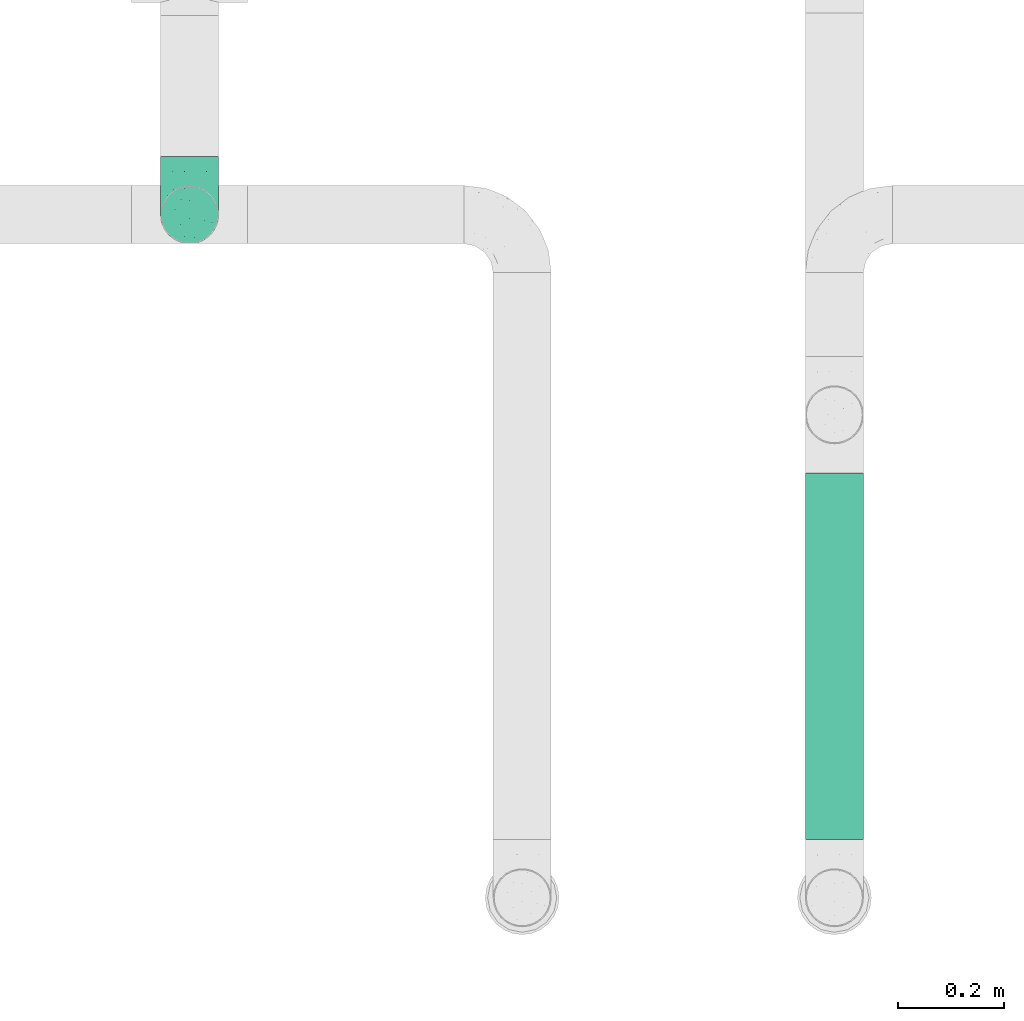
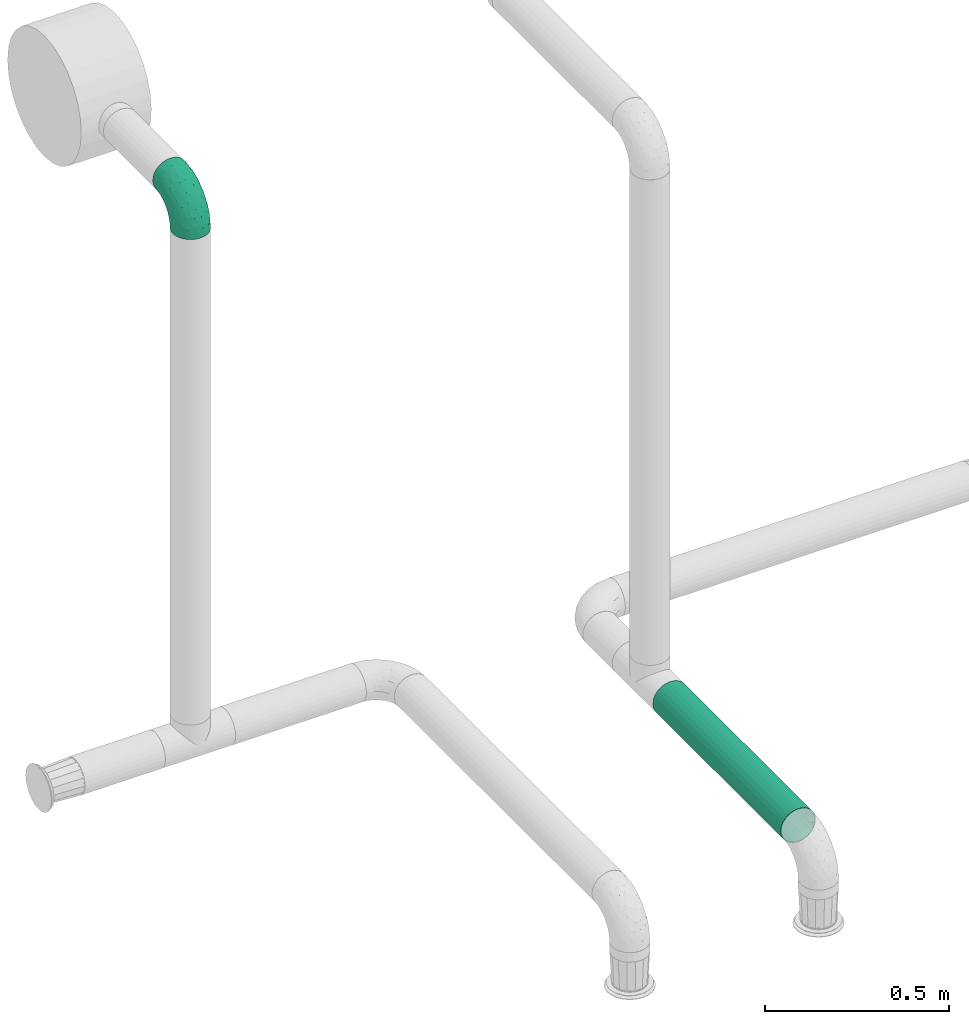
# One storey, part 80 of 103: 1 flow fitting, 1 flow segment.
"""IFC2X3 building model written with IfcOpenShell, lengths in millimetres."""

import ifcopenshell
import ifcopenshell.guid

model = None  # the IFC model being written
_history = None  # IfcOwnerHistory: only IFC2X3 demands one
_inside = {}  # id of a spatial element -> (the spatial element, [elements in it])
_under = {}  # id of a project, library or spatial element -> (it, [spatial elements below it])
_declared = {}  # id of a project -> (the project, [libraries it declares])
_typed = {}  # id of a type object -> (the type object, [elements of that type])
_made_of = {}  # id of a material, layer set ... -> (it, [elements and type objects made of it])


def new_model(schema):
    """Start an empty IFC model of exactly this schema.

    Asked for "IFC4X3", IfcOpenShell would pick the latest addendum, in which some entities
    have other attributes; the version numbers below select the first issue.
    IFC2X3 requires an IfcOwnerHistory on every rooted entity: one is made here for all.
    """
    global model, _history
    if schema == "IFC4X3":
        model = ifcopenshell.file(schema_version=(4, 3, 0, 0))
    else:
        model = ifcopenshell.file(schema=schema)
    _inside.clear()
    _under.clear()
    _declared.clear()
    _typed.clear()
    _made_of.clear()
    _history = None
    if model.schema == "IFC2X3":
        org = make("IfcOrganization", Name="unknown")
        user = make(
            "IfcPersonAndOrganization",
            ThePerson=make("IfcPerson", FamilyName="unknown"),
            TheOrganization=org,
        )
        app = make(
            "IfcApplication",
            ApplicationDeveloper=org,
            Version="unknown",
            ApplicationFullName="unknown",
            ApplicationIdentifier="unknown",
        )
        _history = make(
            "IfcOwnerHistory",
            OwningUser=user,
            OwningApplication=app,
            ChangeAction="ADDED",
            CreationDate=0,
        )
    return model


def make(cls, **values):
    """One entity of the class cls with the attributes given. An attribute that is None is left unset."""
    return model.create_entity(
        cls, **{name: value for name, value in values.items() if value is not None}
    )


def entity(cls, *values):
    """Any entity or typed value of the class cls, its attributes in the order of the schema. None: left unset."""
    e = model.create_entity(cls)
    for i, value in enumerate(values):
        if value is not None:
            e[i] = value
    return e


def rooted(cls, **values):
    """An entity with a GlobalId (a new one), such as an element, a storey or a relation."""
    return make(cls, GlobalId=ifcopenshell.guid.new(), OwnerHistory=_history, **values)


def si_unit(unit_type, name, prefix=None):
    """IfcSIUnit, for example si_unit("LENGTHUNIT", "METRE", prefix="MILLI")."""
    return make("IfcSIUnit", UnitType=unit_type, Prefix=prefix, Name=name)


def converted_unit(unit_type, name, factor, base, dimensions=None, offset=None):
    """IfcConversionBasedUnit, such as the inch: factor (a typed value) times the base unit."""
    return make(
        "IfcConversionBasedUnit"
        if offset is None
        else "IfcConversionBasedUnitWithOffset",
        ConversionOffset=offset,
        Dimensions=None
        if dimensions is None
        else entity("IfcDimensionalExponents", *dimensions),
        UnitType=unit_type,
        Name=name,
        ConversionFactor=make(
            "IfcMeasureWithUnit", ValueComponent=factor, UnitComponent=base
        ),
    )


def derived_unit(unit_type, elements):
    """IfcDerivedUnit: a product of units, each with its exponent."""
    return make(
        "IfcDerivedUnit",
        Elements=[
            make("IfcDerivedUnitElement", Unit=unit, Exponent=power)
            for unit, power in elements
        ],
        UnitType=unit_type,
    )


def assignment(units):
    """IfcUnitAssignment: the units of a project."""
    return None if units is None else make("IfcUnitAssignment", Units=units)


def point(xyz):
    """IfcCartesianPoint."""
    return None if xyz is None else make("IfcCartesianPoint", Coordinates=xyz)


def direction(xyz):
    """IfcDirection."""
    return None if xyz is None else make("IfcDirection", DirectionRatios=xyz)


def frame(location, z_axis=None, x_axis=None):
    """IfcAxis2Placement3D, a coordinate frame: its origin and axes. An axis left out is left unset."""
    return make(
        "IfcAxis2Placement3D",
        Location=point(location),
        Axis=direction(z_axis),
        RefDirection=direction(x_axis),
    )


def frame_2d(location, x_axis=None):
    """IfcAxis2Placement2D, a coordinate frame in the plane: its origin and x axis."""
    return make(
        "IfcAxis2Placement2D", Location=point(location), RefDirection=direction(x_axis)
    )


def origin_with_axes():
    """The frame at (0, 0, 0) with the z axis (0, 0, 1) and the x axis (1, 0, 0) written out."""
    return frame((0.0, 0.0, 0.0), z_axis=(0.0, 0.0, 1.0), x_axis=(1.0, 0.0, 0.0))


def origin_2d_with_axis():
    """The frame at (0, 0) in the plane with the x axis (1, 0) written out."""
    return frame_2d((0.0, 0.0), x_axis=(1.0, 0.0))


def place(relative_to, where):
    """IfcLocalPlacement: puts the frame where relative to a parent placement (None: the world)."""
    return make(
        "IfcLocalPlacement", PlacementRelTo=relative_to, RelativePlacement=where
    )


def context(
    kind, dimensions, precision=None, world=None, true_north=None, identifier=None
):
    """IfcGeometricRepresentationContext, for example the 3D "Model" context."""
    return make(
        "IfcGeometricRepresentationContext",
        ContextIdentifier=identifier,
        ContextType=kind,
        CoordinateSpaceDimension=dimensions,
        Precision=precision,
        WorldCoordinateSystem=world,
        TrueNorth=true_north,
    )


def subcontext(parent, identifier, kind, view, scale=None):
    """IfcGeometricRepresentationSubContext, for example "Body" below "Model"."""
    return make(
        "IfcGeometricRepresentationSubContext",
        ContextIdentifier=identifier,
        ContextType=kind,
        ParentContext=parent,
        TargetScale=scale,
        TargetView=view,
    )


def project(units=None, contexts=None):
    """IfcProject with its units and contexts."""
    return rooted(
        "IfcProject",
        Name="project",
        RepresentationContexts=contexts,
        UnitsInContext=assignment(units),
    )


def spatial(cls, under=None, at=None, **own):
    """A site, building, storey or space (cls), placed at a placement, below another one or the project."""
    s = rooted(cls, ObjectPlacement=at, **own)
    if under is not None:
        _under.setdefault(under.id(), (under, []))[1].append(s)
    return s


def profile(cls, at=None, kind="AREA", **sizes):
    """A parametric profile (cls). Its sizes go by their IFC names, for example OverallWidth=200.0."""
    return make(cls, ProfileType=kind, Position=at, **sizes)


def hollow_circle(**sizes):
    """IfcCircleHollowProfileDef."""
    return profile("IfcCircleHollowProfileDef", **sizes)


def extrude(swept, where, along, depth):
    """IfcExtrudedAreaSolid: the profile swept, set in the frame where, extruded along a direction by depth."""
    return make(
        "IfcExtrudedAreaSolid",
        SweptArea=swept,
        Position=where,
        ExtrudedDirection=direction(along),
        Depth=depth,
    )


def faces_of(points, faces, orient=None, outer=None):
    """IfcFace entities. A face is a list of loops; a loop is a list of indices into points, from 0.

    orient and outer hold one flag for each loop. By default every Orientation is true, the
    first loop of a face is its IfcFaceOuterBound and the others are IfcFaceBound.
    """
    made = []
    for i, loops in enumerate(faces):
        bounds = []
        for j, loop in enumerate(loops):
            is_outer = j == 0 if outer is None else outer[i][j]
            bounds.append(
                make(
                    "IfcFaceOuterBound" if is_outer else "IfcFaceBound",
                    Bound=make("IfcPolyLoop", Polygon=[points[k] for k in loop]),
                    Orientation=True if orient is None else orient[i][j],
                )
            )
        made.append(make("IfcFace", Bounds=bounds))
    return made


def open_shell(faces, orient=None, outer=None):
    """The faces of one IfcOpenShell. surface_model builds it on its shared points."""
    return ("IfcOpenShell", faces, orient, outer)


def surface_model(cls, points, shells):
    """IfcFaceBasedSurfaceModel or IfcShellBasedSurfaceModel (cls): surfaces that need not close."""
    shared = [point(p) for p in points]
    made = [make(c, CfsFaces=faces_of(shared, fs, o, b)) for c, fs, o, b in shells]
    if cls == "IfcFaceBasedSurfaceModel":
        return make(cls, FbsmFaces=made)
    return make(cls, SbsmBoundary=made)


def shape(context_of_items, identifier, shape_type, items):
    """IfcShapeRepresentation: the items that make up one representation, for example the "Body"."""
    return make(
        "IfcShapeRepresentation",
        ContextOfItems=context_of_items,
        RepresentationIdentifier=identifier,
        RepresentationType=shape_type,
        Items=items,
    )


def source(mapping_origin, context_of_items, identifier, shape_type, items):
    """IfcRepresentationMap: a shape defined once, which mapped items show again and again."""
    return make(
        "IfcRepresentationMap",
        MappingOrigin=mapping_origin,
        MappedRepresentation=shape(context_of_items, identifier, shape_type, items),
    )


def transform(
    local_origin,
    x_axis=None,
    y_axis=None,
    z_axis=None,
    scale=None,
    scale2=None,
    scale3=None,
    uniform=True,
):
    """IfcCartesianTransformationOperator3D, or its non-uniform kind. x_axis, y_axis, z_axis: its Axis1, 2, 3."""
    if uniform:
        return make(
            "IfcCartesianTransformationOperator3D",
            Axis1=direction(x_axis),
            Axis2=direction(y_axis),
            LocalOrigin=point(local_origin),
            Scale=scale,
            Axis3=direction(z_axis),
        )
    return make(
        "IfcCartesianTransformationOperator3DnonUniform",
        Axis1=direction(x_axis),
        Axis2=direction(y_axis),
        LocalOrigin=point(local_origin),
        Scale=scale,
        Axis3=direction(z_axis),
        Scale2=scale2,
        Scale3=scale3,
    )


def mapped(mapping_source, mapping_target):
    """IfcMappedItem: shows the shape of a source again, moved by a transform."""
    return make(
        "IfcMappedItem", MappingSource=mapping_source, MappingTarget=mapping_target
    )


def material(Name=None, Category=None):
    """IfcMaterial."""
    return make("IfcMaterial", Name=Name, Category=Category)


def layer(
    of_material, thickness, ventilated=None, Name=None, Category=None, Priority=None
):
    """IfcMaterialLayer: one layer of a wall or slab, of a material (None: an air gap)."""
    return make(
        "IfcMaterialLayer",
        Material=of_material,
        LayerThickness=thickness,
        IsVentilated=ventilated,
        Name=Name,
        Category=Category,
        Priority=Priority,
    )


def layer_set(layers, Name=None):
    """IfcMaterialLayerSet."""
    return make("IfcMaterialLayerSet", MaterialLayers=layers, LayerSetName=Name)


def layer_usage(for_layer_set, set_direction, sense, offset, extent=None):
    """IfcMaterialLayerSetUsage: how a layer set lies in its element."""
    return make(
        "IfcMaterialLayerSetUsage",
        ForLayerSet=for_layer_set,
        LayerSetDirection=set_direction,
        DirectionSense=sense,
        OffsetFromReferenceLine=offset,
        ReferenceExtent=extent,
    )


def made_of(thing, what):
    """Note that an element or type object is made of a material, layer set ...; save() writes the relation."""
    if what is not None:
        _made_of.setdefault(what.id(), (what, []))[1].append(thing)
    return thing


def type_object(cls, material=None, **own):
    """A type object (cls), such as IfcWallType, which elements share."""
    return made_of(rooted(cls, **own), material)


def element(
    cls,
    number,
    at=None,
    inside=None,
    cuts=None,
    type_object=None,
    material=None,
    context=None,
    identifier="Body",
    shape_type=None,
    held_by="IfcProductDefinitionShape",
    body=None,
    shapes=None,
    **own,
):
    """One element of the class cls, such as IfcWall. Its Tag is "e" and its number.

    at: its placement. inside: the storey or other place that contains it. cuts: it is an
    opening in that element (IfcRelVoidsElement). A single representation is given by context,
    identifier, shape_type and body (its items); several are given by shapes. held_by: the class
    of the entity that holds the representations. save() writes the other relations.
    """
    e = rooted(cls, Tag="e%d" % number, ObjectPlacement=at, **own)
    if body is not None:
        shapes = [shape(context, identifier, shape_type, body)]
    if shapes is not None:
        e.Representation = make(held_by, Representations=shapes)
    if inside is not None:
        _inside.setdefault(inside.id(), (inside, []))[1].append(e)
    if cuts is not None:
        rooted(
            "IfcRelVoidsElement", RelatingBuildingElement=cuts, RelatedOpeningElement=e
        )
    if type_object is not None:
        _typed.setdefault(type_object.id(), (type_object, []))[1].append(e)
    return made_of(e, material)


def aggregate(whole, parts):
    """IfcRelAggregates: a whole, such as a stair, and the parts it consists of."""
    return rooted("IfcRelAggregates", RelatingObject=whole, RelatedObjects=parts)


def save(model, path):
    """Write the relations noted so far, then the file.

    IfcRelAggregates (storeys below a building ...), IfcRelContainedInSpatialStructure (elements
    in a storey), IfcRelDefinesByType, IfcRelAssociatesMaterial and IfcRelDeclares: one each for
    every whole, place, type object, material and project.
    """
    for whole, parts in _under.values():
        aggregate(whole, parts)
    for where, things in _inside.values():
        rooted(
            "IfcRelContainedInSpatialStructure",
            RelatedElements=things,
            RelatingStructure=where,
        )
    for kind, things in _typed.values():
        rooted("IfcRelDefinesByType", RelatedObjects=things, RelatingType=kind)
    for what, things in _made_of.values():
        rooted("IfcRelAssociatesMaterial", RelatedObjects=things, RelatingMaterial=what)
    for by, libraries in _declared.values():
        rooted("IfcRelDeclares", RelatingContext=by, RelatedDefinitions=libraries)
    model.write(path)


model = new_model("IFC2X3")

# Units and contexts
model_context = context("Model", 3, precision=1e-05, world=origin_with_axes(), true_north=direction((0.0, 1.0)))
body_context = subcontext(model_context, "Body", "Model", "MODEL_VIEW")
ifc_project = project(units=[si_unit("AREAUNIT", "SQUARE_METRE"), si_unit("VOLUMEUNIT", "CUBIC_METRE", prefix="DECI"), si_unit("TIMEUNIT", "SECOND"), si_unit("THERMODYNAMICTEMPERATUREUNIT", "DEGREE_CELSIUS"), si_unit("PRESSUREUNIT", "PASCAL"), si_unit("MASSUNIT", "GRAM", prefix="KILO"), si_unit("LENGTHUNIT", "METRE", prefix="MILLI"), si_unit("POWERUNIT", "WATT"), si_unit("ELECTRICCURRENTUNIT", "AMPERE"), si_unit("ELECTRICVOLTAGEUNIT", "VOLT"), derived_unit("VOLUMETRICFLOWRATEUNIT", [(si_unit("VOLUMEUNIT", "CUBIC_METRE", prefix="DECI"), 1), (si_unit("TIMEUNIT", "SECOND"), -1)]), derived_unit("LINEARVELOCITYUNIT", [(si_unit("LENGTHUNIT", "METRE"), 1), (si_unit("TIMEUNIT", "SECOND"), -1)]), derived_unit("MASSDENSITYUNIT", [(si_unit("MASSUNIT", "GRAM", prefix="KILO"), 1), (si_unit("VOLUMEUNIT", "CUBIC_METRE"), -1)]), converted_unit("PLANEANGLEUNIT", "DEGREE", entity("IfcRatioMeasure", 0.01745), si_unit("PLANEANGLEUNIT", "RADIAN"), dimensions=[0, 0, 0, 0, 0, 0, 0])], contexts=[model_context])

# Site, building, storey
site_placement = place(None, origin_with_axes())
site = spatial("IfcSite", under=ifc_project, at=site_placement, CompositionType="ELEMENT")
building_placement = place(site_placement, origin_with_axes())
building = spatial("IfcBuilding", under=site, at=building_placement, Name="mc-building", CompositionType="ELEMENT")
storey_placement = place(building_placement, frame((0.0, 0.0, 5900.0), z_axis=(0.0, 0.0, 1.0), x_axis=(1.0, 0.0, 0.0)))
storey = spatial("IfcBuildingStorey", under=building, at=storey_placement, Name="3. Korrus", CompositionType="ELEMENT", Elevation=5900.0)

# Flow segment
ifc_material = material(Name="FZ1")
ifc_layer = layer(ifc_material, 0.0)
ifc_layer_set = layer_set([ifc_layer], Name="FZ1")
ifc_layer_usage = layer_usage(ifc_layer_set, "AXIS1", "POSITIVE", 0.0)
duct_segment_type = type_object("IfcDuctSegmentType", Name="Safe", PredefinedType="RIGIDSEGMENT")
shared_shape_1 = source(origin_with_axes(), body_context, "Body", "SweptSolid", [
    extrude(hollow_circle(Radius=55.0, WallThickness=2.0, at=origin_2d_with_axis()), frame((0.0, 0.0, 0.0), z_axis=(1.0, 0.0, 0.0), x_axis=(0.0, 1.0, 0.0)), (0.0, 0.0, 1.0), 695.0),
])
flow_segment_placement = place(storey_placement, frame((26894.1474, 8988.55564, 2345.0), z_axis=(0.0, 0.0, 1.0), x_axis=(0.0, -1.0, 0.0)))
element("IfcFlowSegment", 1, at=flow_segment_placement, inside=storey, type_object=duct_segment_type, material=ifc_layer_usage, Name="Safe", context=body_context, shape_type="MappedRepresentation", body=[
    mapped(shared_shape_1, transform((0.0, 0.0, 0.0), scale=1.0)),
])

# Flow fitting
duct_fitting_type = type_object("IfcDuctFittingType", Name="BU", PredefinedType="BEND")
shared_shape_2 = source(origin_with_axes(), body_context, "Body", "SurfaceModel", [
    surface_model("IfcShellBasedSurfaceModel", [(-110.0, 0.0, -55.0), (-110.0, -14.23505, -53.12592), (-110.0, 14.23505, -53.12592), (-110.0, 53.12592, 14.23505), (-110.0, 27.5, -47.63139), (-110.0, 38.89087, -38.89087), (-110.0, -55.0, 0.0), (-110.0, -53.12592, 14.23505), (-110.0, -38.89087, -38.89087), (-110.0, -27.5, -47.63139), (-110.0, -53.12592, -14.23505), (-110.0, -47.63139, -27.5), (-110.0, -14.23505, 53.12592), (-110.0, 14.23505, 53.12592), (-110.0, 27.5, 47.63139), (-110.0, -47.63139, 27.5), (-110.0, -38.89087, 38.89087), (-110.0, -27.5, 47.63139), (-110.0, 0.0, 55.0), (-110.0, 55.0, 0.0), (-110.0, 53.12592, -14.23505), (-110.0, 47.63139, -27.5), (-110.0, 47.63139, 27.5), (-110.0, 38.89087, 38.89087), (-14.23505, 110.0, -53.12592), (-55.0, 110.0, 0.0), (0.0, 110.0, -55.0), (-27.5, 110.0, -47.63139), (-38.89087, 110.0, -38.89087), (-47.63139, 110.0, -27.5), (38.89087, 110.0, -38.89087), (53.12592, 110.0, 14.23505), (27.5, 110.0, -47.63139), (14.23505, 110.0, -53.12592), (47.63139, 110.0, -27.5), (53.12592, 110.0, -14.23505), (55.0, 110.0, 0.0), (-53.12592, 110.0, -14.23505), (-53.12592, 110.0, 14.23505), (-47.63139, 110.0, 27.5), (-38.89087, 110.0, 38.89087), (-27.5, 110.0, 47.63139), (0.0, 110.0, 55.0), (-14.23505, 110.0, 53.12592), (38.89087, 110.0, 38.89087), (47.63139, 110.0, 27.5), (27.5, 110.0, 47.63139), (14.23505, 110.0, 53.12592), (-64.21732, 48.68956, 43.63444), (-76.6405, 38.18013, 45.55988), (-60.44912, 32.56953, 51.94617), (-76.00813, 5.38378, 55.0), (-90.15553, 11.94394, 54.09138), (-78.5998, 26.77405, 50.81338), (-70.18771, 18.55163, 54.03432), (-75.55424, 54.2118, 32.41257), (-93.27622, 45.77614, 33.48188), (-96.12334, 22.13664, 50.81337), (-21.00813, 45.34362, 55.0), (-18.36258, 70.48427, 54.04484), (-32.04182, 59.64019, 52.24446), (-63.88653, 74.77858, 17.99134), (-74.66383, 63.08407, 19.92123), (-63.60674, 66.07878, 29.97482), (-99.597, 52.72185, 18.52927), (-93.11138, 56.59448, 10.50359), (-98.21577, 57.34403, 0.0), (-53.42855, 92.60092, 21.04759), (-88.54852, 54.8376, 21.04759), (-11.86161, 90.23965, 54.10313), (-5.38378, 76.00813, 55.0), (-57.34403, 98.21577, 0.0), (-56.64619, 93.12774, 10.22088), (-45.34362, 21.00813, 55.0), (-44.60838, 44.60838, 52.13415), (-92.68484, 35.46673, 43.63443), (-22.25266, 95.40765, 50.81337), (-35.97783, 90.61597, 43.63443), (-43.70931, 69.58671, 44.47149), (-27.23711, 77.39884, 50.81337), (-57.2828, 79.3123, 24.9774), (-58.67786, 84.31125, 16.04456), (-82.93277, 60.36161, 12.91784), (-49.88337, 54.51816, 47.224), (-74.57753, 66.83759, 9.55742), (-45.35812, 94.97281, 33.48188), (-59.18663, 88.95241, 0.0), (-51.517, 78.6292, 33.48188), (-65.14788, 80.03077, 0.0), (-56.45322, 62.06476, 39.63545), (-88.95241, 59.18663, 0.0), (-71.10913, 71.10913, 0.0), (-80.03077, 65.14788, 0.0), (-94.9309, 45.36788, -33.48188), (-93.11358, 56.60141, -10.46614), (-99.64997, 52.79499, -18.30015), (-90.20425, 36.08686, -43.63443), (-79.99933, 46.56772, -37.92748), (-76.00813, 5.38378, -55.0), (-72.75364, 19.68651, -53.60527), (-45.34362, 21.00813, -55.0), (-21.91957, 65.12078, -53.85897), (-5.38378, 76.00813, -55.0), (-21.00813, 45.34362, -55.0), (-35.41876, 92.89265, -43.63443), (-91.10309, 11.02766, -54.21832), (-45.77614, 93.27622, -33.48188), (-90.50474, 23.21022, -50.81337), (-70.92854, 33.31794, -49.51754), (-78.52933, 63.35627, -11.73997), (-24.91508, 84.05606, -50.81337), (-88.78941, 54.74452, -21.04759), (-69.59921, 57.34866, -33.48187), (-73.36422, 62.46673, -22.94182), (-63.49062, 67.59111, -28.46929), (-56.59448, 93.11138, -10.50359), (-54.8376, 88.54852, -21.04759), (-54.10679, 75.85581, -32.31867), (-57.75956, 31.09612, -52.80882), (-52.72185, 99.597, -18.52927), (-12.62913, 89.46304, -53.99097), (-34.46825, 66.46123, -50.04329), (-43.9837, 43.9837, -52.42279), (-65.78527, 72.58348, -17.68796), (-70.34468, 43.65295, -44.21951), (-57.47001, 51.99467, -44.91465), (-60.72547, 82.29174, -12.88567), (-42.34915, 74.24548, -43.63444), (-57.25194, 63.5016, -38.08211), (-80.95344, 53.56991, -29.32027), (-52.32891, 4.55257, -54.0482), (32.52942, 47.13398, -30.48571), (14.88266, 20.92917, -33.7947), (14.95561, 36.05775, -42.26543), (30.24048, 70.09027, -41.7461), (19.3559, 65.35825, -48.00507), (-70.35075, -46.44478, -19.5952), (-47.13398, -32.52942, -30.48571), (-28.49299, -30.5778, -16.4009), (-4.55257, 52.32891, -54.0482), (-22.4954, 22.4954, -53.25347), (-75.47368, -11.22546, -52.60718), (-81.32209, -51.5606, -9.98467), (-80.81763, -41.84862, -32.14655), (-70.09027, -30.24048, -41.7461), (-36.05774, -14.95561, -42.26543), (-9.15831, -10.852, -27.8997), (-65.35825, -19.3559, -48.00507), (11.22546, 75.47368, -52.60718), (3.94376, 43.9333, -50.53315), (-13.39742, 13.39743, -48.13058), (-43.9333, -3.94376, -50.53315), (49.37776, 67.29486, 0.0), (41.8609, 47.82256, -9.92641), (50.20582, 74.51695, -9.9731), (18.93131, 11.7156, -17.56239), (-27.5, -32.89419, 0.0), (-1.23348, -12.25375, -12.18106), (41.84862, 80.81763, -32.14655), (35.70604, 41.31408, -20.38235), (46.44478, 70.35075, -19.5952), (32.89419, 27.5, 0.0), (6.67262, -6.67262, 0.0), (-67.29486, -49.37776, 0.0), (-50.36265, -42.95545, -9.51562), (-5.47251, 5.47251, -39.92906), (-70.35075, -46.44478, 19.5952), (-74.51695, -50.20582, 9.9731), (-41.31407, -35.70604, 20.38235), (-47.13398, -32.52942, 30.48571), (-80.81763, -41.84862, 32.14655), (-4.55257, 52.32891, 54.0482), (11.22546, 75.47368, 52.60718), (-43.9333, -3.94376, 50.53315), (-65.35825, -19.3559, 48.00507), (-36.05774, -14.95561, 42.26543), (-70.09027, -30.24048, 41.7461), (-11.7156, -18.93131, 17.56239), (30.5778, 28.49299, 16.4009), (12.25375, 1.23348, 12.18106), (51.5606, 81.32209, 9.98467), (42.95545, 50.36265, 9.51562), (-75.47368, -11.22546, 52.60718), (-52.32891, 4.55257, 54.0482), (3.94376, 43.9333, 50.53315), (-22.4954, 22.4954, 53.25347), (-13.39742, 13.39743, 48.13058), (10.852, 9.15831, 27.8997), (-20.92916, -14.88266, 33.79469), (-47.82256, -41.8609, 9.92641), (32.52942, 47.13398, 30.48571), (46.44478, 70.35075, 19.5952), (41.84862, 80.81763, 32.14655), (30.24048, 70.09027, 41.7461), (19.3559, 65.35825, 48.00507), (14.95561, 36.05775, 42.26543), (-5.47251, 5.47251, 39.92906)], [open_shell([[[0, 1, 2]], [[2, 3, 4]], [[4, 3, 5]], [[2, 6, 7]], [[8, 6, 9]], [[1, 9, 6]], [[10, 6, 11]], [[8, 11, 6]], [[6, 2, 1]], [[12, 13, 14]], [[15, 2, 7]], [[16, 17, 2]], [[2, 17, 12]], [[12, 18, 13]], [[19, 20, 3]], [[5, 3, 21]], [[20, 21, 3]], [[22, 3, 2]], [[23, 22, 2]], [[12, 14, 2]], [[2, 14, 23]], [[15, 16, 2]], [[24, 25, 26]], [[27, 25, 24]], [[25, 28, 29]], [[28, 25, 27]], [[30, 26, 31]], [[26, 30, 32]], [[32, 33, 26]], [[34, 31, 35]], [[31, 34, 30]], [[35, 31, 36]], [[29, 37, 25]], [[38, 39, 26]], [[39, 40, 26]], [[41, 42, 40]], [[42, 26, 40]], [[42, 41, 43]], [[26, 44, 45]], [[31, 26, 45]], [[26, 46, 44]], [[47, 46, 26]], [[42, 47, 26]], [[25, 38, 26]], [[48, 49, 50]], [[18, 51, 52]], [[53, 54, 50]], [[55, 56, 49]], [[56, 22, 23]], [[13, 57, 14]], [[58, 59, 60]], [[61, 62, 63]], [[3, 64, 65]], [[53, 52, 54]], [[3, 65, 66]], [[67, 39, 38]], [[56, 68, 64]], [[65, 64, 68]], [[69, 59, 70]], [[38, 71, 72]], [[73, 58, 74]], [[75, 49, 56]], [[76, 69, 43]], [[53, 57, 52]], [[77, 78, 79]], [[41, 76, 43]], [[43, 69, 42]], [[55, 68, 56]], [[23, 14, 75]], [[76, 77, 79]], [[80, 67, 81]], [[62, 82, 68]], [[60, 78, 83]], [[62, 84, 82]], [[85, 77, 40]], [[81, 67, 72]], [[86, 72, 71]], [[87, 85, 67]], [[61, 81, 88]], [[77, 41, 40]], [[78, 77, 87]], [[23, 75, 56]], [[83, 89, 48]], [[85, 40, 39]], [[62, 68, 55]], [[89, 87, 63]], [[83, 48, 50]], [[57, 75, 14]], [[49, 75, 53]], [[67, 85, 39]], [[87, 77, 85]], [[63, 62, 55]], [[89, 55, 48]], [[80, 63, 87]], [[66, 65, 90]], [[66, 19, 3]], [[84, 91, 92]], [[92, 90, 82]], [[65, 82, 90]], [[61, 84, 62]], [[92, 82, 84]], [[68, 82, 65]], [[3, 22, 64]], [[56, 64, 22]], [[38, 25, 71]], [[81, 72, 86]], [[38, 72, 67]], [[91, 61, 88]], [[80, 81, 61]], [[63, 80, 61]], [[67, 80, 87]], [[77, 76, 41]], [[79, 59, 69]], [[79, 69, 76]], [[42, 69, 70]], [[60, 59, 79]], [[58, 70, 59]], [[78, 60, 79]], [[58, 60, 74]], [[52, 57, 13]], [[75, 57, 53]], [[18, 52, 13]], [[52, 51, 54]], [[51, 73, 54]], [[50, 73, 74]], [[73, 50, 54]], [[50, 74, 83]], [[60, 83, 74]], [[89, 83, 78]], [[87, 89, 78]], [[55, 89, 63]], [[50, 49, 53]], [[55, 49, 48]], [[81, 86, 88]], [[91, 84, 61]], [[5, 21, 93]], [[90, 94, 66]], [[20, 94, 95]], [[96, 93, 97]], [[98, 99, 100]], [[96, 4, 5]], [[101, 102, 103]], [[28, 27, 104]], [[2, 105, 0]], [[104, 106, 28]], [[99, 105, 107]], [[108, 107, 96]], [[90, 109, 94]], [[107, 2, 4]], [[20, 66, 94]], [[27, 24, 110]], [[109, 111, 94]], [[112, 113, 114]], [[37, 115, 71]], [[116, 106, 117]], [[99, 118, 100]], [[116, 115, 119]], [[37, 119, 115]], [[24, 120, 110]], [[121, 110, 101]], [[119, 106, 116]], [[101, 110, 120]], [[122, 103, 100]], [[117, 123, 116]], [[124, 125, 108]], [[115, 116, 126]], [[106, 29, 28]], [[26, 102, 120]], [[127, 104, 110]], [[97, 124, 96]], [[125, 122, 118]], [[128, 127, 125]], [[96, 5, 93]], [[115, 126, 86]], [[117, 106, 127]], [[111, 113, 129]], [[95, 93, 21]], [[97, 129, 112]], [[110, 104, 27]], [[106, 104, 127]], [[96, 107, 4]], [[99, 107, 108]], [[99, 108, 118]], [[105, 99, 98]], [[112, 114, 128]], [[121, 125, 127]], [[20, 19, 66]], [[109, 90, 92]], [[94, 111, 95]], [[91, 123, 109]], [[129, 113, 112]], [[93, 95, 111]], [[21, 20, 95]], [[71, 115, 86]], [[71, 25, 37]], [[123, 91, 88]], [[126, 116, 123]], [[123, 88, 126]], [[86, 126, 88]], [[37, 29, 119]], [[106, 119, 29]], [[129, 93, 111]], [[124, 112, 125]], [[0, 105, 98]], [[107, 105, 2]], [[125, 118, 108]], [[100, 118, 122]], [[93, 129, 97]], [[113, 111, 109]], [[109, 123, 113]], [[114, 123, 117]], [[123, 114, 113]], [[128, 114, 117]], [[127, 128, 117]], [[112, 128, 125]], [[103, 122, 101]], [[110, 121, 127]], [[101, 122, 121]], [[125, 121, 122]], [[26, 120, 24]], [[101, 120, 102]], [[96, 124, 108]], [[92, 91, 109]], [[112, 124, 97]], [[100, 130, 98]], [[131, 132, 133]], [[32, 134, 135]], [[136, 137, 138]], [[139, 140, 103]], [[98, 141, 0]], [[142, 10, 136]], [[143, 144, 137]], [[6, 10, 142]], [[137, 145, 146]], [[144, 147, 145]], [[143, 136, 11]], [[11, 136, 10]], [[8, 143, 11]], [[148, 149, 139]], [[8, 9, 144]], [[9, 1, 147]], [[130, 141, 98]], [[103, 140, 100]], [[148, 135, 149]], [[150, 151, 140]], [[152, 153, 154]], [[130, 140, 151]], [[148, 26, 33]], [[147, 1, 141]], [[155, 146, 132]], [[156, 138, 157]], [[134, 30, 158]], [[150, 140, 149]], [[158, 30, 34]], [[30, 134, 32]], [[153, 159, 160]], [[131, 160, 159]], [[144, 145, 137]], [[36, 152, 154]], [[146, 138, 137]], [[155, 161, 162]], [[158, 160, 131]], [[133, 149, 135]], [[156, 163, 164]], [[163, 142, 164]], [[139, 103, 102]], [[153, 152, 161]], [[34, 35, 160]], [[162, 157, 155]], [[132, 165, 133]], [[157, 146, 155]], [[140, 130, 100]], [[141, 130, 151]], [[141, 151, 147]], [[141, 1, 0]], [[102, 26, 148]], [[140, 139, 149]], [[102, 148, 139]], [[135, 33, 32]], [[151, 150, 145]], [[9, 147, 144]], [[151, 145, 147]], [[145, 165, 146]], [[135, 148, 33]], [[133, 135, 134]], [[131, 133, 134]], [[133, 165, 150]], [[133, 150, 149]], [[145, 150, 165]], [[132, 131, 159]], [[146, 165, 132]], [[160, 158, 34]], [[134, 158, 131]], [[144, 143, 8]], [[136, 143, 137]], [[155, 153, 161]], [[154, 153, 160]], [[153, 155, 159]], [[132, 159, 155]], [[160, 35, 154]], [[36, 154, 35]], [[164, 136, 138]], [[6, 142, 163]], [[136, 164, 142]], [[156, 164, 138]], [[156, 157, 162]], [[146, 157, 138]], [[15, 7, 166]], [[6, 163, 167]], [[168, 169, 166]], [[166, 169, 170]], [[171, 172, 70]], [[173, 174, 175]], [[17, 176, 174]], [[177, 156, 162]], [[176, 16, 170]], [[170, 16, 15]], [[161, 178, 179]], [[152, 180, 181]], [[182, 173, 183]], [[18, 12, 182]], [[184, 185, 186]], [[183, 185, 73]], [[183, 73, 51]], [[177, 187, 188]], [[189, 168, 166]], [[187, 178, 190]], [[16, 176, 17]], [[161, 152, 181]], [[45, 191, 31]], [[45, 44, 192]], [[192, 191, 45]], [[180, 36, 31]], [[193, 194, 195]], [[46, 47, 194]], [[193, 195, 190]], [[193, 44, 46]], [[172, 42, 70]], [[185, 58, 73]], [[189, 163, 156]], [[163, 189, 167]], [[70, 58, 171]], [[184, 171, 185]], [[169, 188, 175]], [[180, 31, 191]], [[192, 193, 190]], [[191, 190, 178]], [[182, 174, 173]], [[194, 47, 172]], [[190, 195, 187]], [[186, 185, 173]], [[162, 179, 177]], [[188, 196, 175]], [[179, 187, 177]], [[185, 171, 58]], [[172, 171, 184]], [[172, 184, 194]], [[172, 47, 42]], [[51, 18, 182]], [[185, 183, 173]], [[51, 182, 183]], [[174, 12, 17]], [[184, 186, 195]], [[46, 194, 193]], [[184, 195, 194]], [[195, 196, 187]], [[174, 182, 12]], [[175, 174, 176]], [[169, 175, 176]], [[175, 196, 186]], [[175, 186, 173]], [[195, 186, 196]], [[188, 169, 168]], [[187, 196, 188]], [[166, 170, 15]], [[176, 170, 169]], [[193, 192, 44]], [[191, 192, 190]], [[177, 189, 156]], [[167, 189, 166]], [[189, 177, 168]], [[188, 168, 177]], [[166, 7, 167]], [[6, 167, 7]], [[181, 191, 178]], [[36, 180, 152]], [[191, 181, 180]], [[161, 181, 178]], [[161, 179, 162]], [[187, 179, 178]]])]),
])
flow_fitting_placement = place(storey_placement, frame((25672.59509, 9477.62755, 4144.0), z_axis=(-1.0, 0.0, 0.0), x_axis=(0.0, 0.0, 1.0)))
element("IfcFlowFitting", 2, at=flow_fitting_placement, inside=storey, type_object=duct_fitting_type, Name="BU", context=body_context, shape_type="MappedRepresentation", body=[
    mapped(shared_shape_2, transform((0.0, 0.0, 0.0), scale=1.0)),
])

save(model, "model.ifc")
